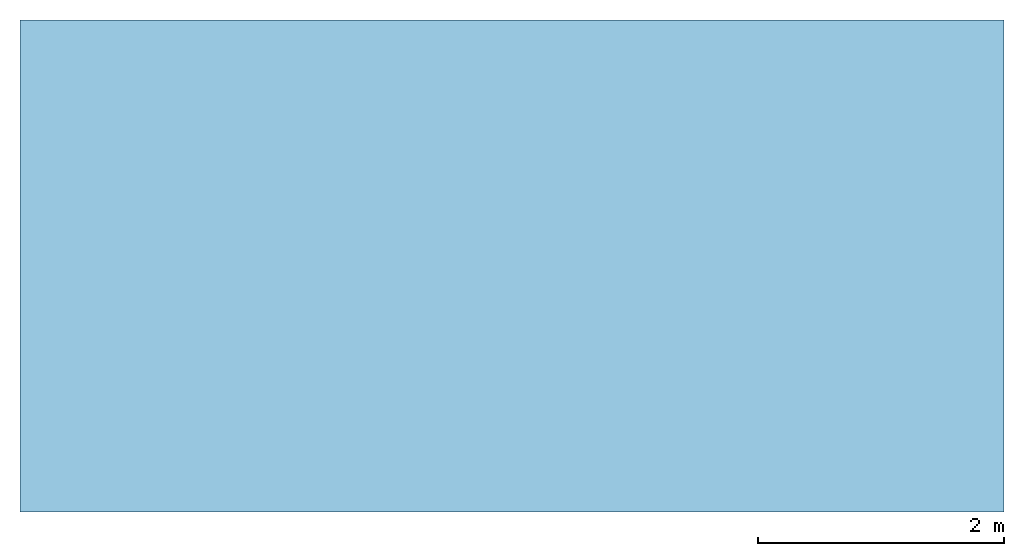
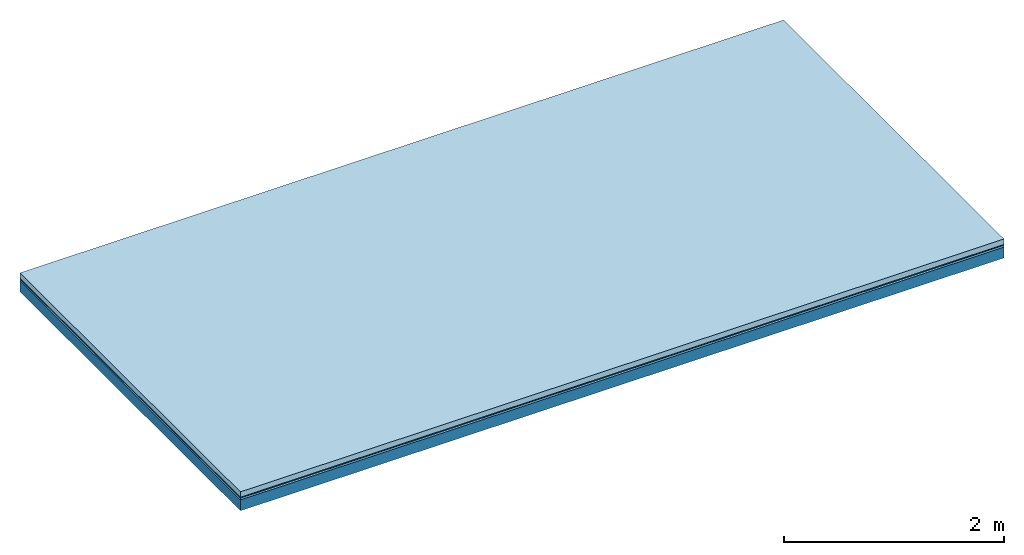
# One storey: 3 plates, 1 member, 1 element without a shape of its own.
"""IFC4 building model written with IfcOpenShell, lengths in metres."""

from ifc_helpers import new_model, si_unit, derived_unit, direction, frame, frame_2d, origin, origin_with_axes, place, context, project, spatial, rectangle, extrude, material, layer, layer_set, type_object, element, aggregate, save


model = new_model("IFC4")

# Units and contexts
plan_context = context("Plan", 3, precision=1e-05, world=origin(), true_north=direction((0.0, 1.0)))
model_context = context("Model", 3, precision=1e-05, world=origin(), true_north=direction((0.0, 1.0)))
ifc_project = project(units=[si_unit("LENGTHUNIT", "METRE"), derived_unit("SOUNDPRESSUREUNIT", [(si_unit("PRESSUREUNIT", "PASCAL", prefix="MICRO"), 0)]), si_unit("ENERGYUNIT", "JOULE", prefix="MEGA"), si_unit("MASSUNIT", "GRAM", prefix="KILO"), derived_unit("THERMALTRANSMITTANCEUNIT", [(si_unit("POWERUNIT", "WATT"), 1), (si_unit("AREAUNIT", "SQUARE_METRE"), -1), (si_unit("THERMODYNAMICTEMPERATUREUNIT", "KELVIN"), -1)]), derived_unit("AREADENSITYUNIT", [(si_unit("MASSUNIT", "GRAM", prefix="KILO"), 1), (si_unit("AREAUNIT", "SQUARE_METRE"), -1)]), derived_unit("USERDEFINED", [(si_unit("ENERGYUNIT", "JOULE", prefix="MEGA"), 1), (si_unit("AREAUNIT", "SQUARE_METRE"), -1)])], contexts=[plan_context, model_context])

# Site, building, storey
site = spatial("IfcSite", under=ifc_project)
building_placement = place(None, origin())
building = spatial("IfcBuilding", under=site, at=building_placement)
storey_placement = place(building_placement, origin())
storey = spatial("IfcBuildingStorey", under=building, at=storey_placement)

# Slab, member, plates
ifc_material_1 = material(Name="clay", Category="02.004")
ifc_layer_1 = layer(ifc_material_1, 0.06, Name="Use and protection layer 2")
ifc_material_2 = material(Name="Protective layer", Category="09.007")
ifc_layer_2 = layer(ifc_material_2, 0.01, Name="Use and protection layer 1")
ifc_material_3 = material(Name="Bituminous", Category="09.003")
ifc_layer_3 = layer(ifc_material_3, 0.02, Name="Seal")
ifc_material_4 = material(Name="no composite action")
ifc_layer_4 = layer(ifc_material_4, 0.0, Name="Bond")
ifc_layer_5 = layer(None, 0.12, Name="Support")
ifc_layer_set = layer_set([ifc_layer_1, ifc_layer_2, ifc_layer_3, ifc_layer_4, ifc_layer_5])
slab_type = type_object("IfcSlabType", Name="F0031", PredefinedType="NOTDEFINED", material=ifc_layer_set)
slab_placement = place(None, frame((0.0, 0.0, 0.0), z_axis=(0.0, 0.0, -1.0), x_axis=(1.0, 0.0, 0.0)))
slab = element("IfcSlab", 1, at=slab_placement, inside=storey, type_object=slab_type, material=ifc_layer_set, Name="Slab #1")
ifc_material_5 = material(Name="Solid timber panel")
member_placement = place(slab_placement, origin())
member = element("IfcMember", 2, at=member_placement, material=ifc_material_5, Name="Support", context=plan_context, shape_type="SweptSolid", body=[
    extrude(rectangle(XDim=1.0, YDim=0.12, at=frame_2d((0.5, 0.06), x_axis=(1.0, 0.0))), frame((0.0, 4.0, 0.09), z_axis=(0.0, -1.0, 0.0), x_axis=(1.0, 0.0, 0.0)), (0.0, 0.0, 1.0), 4.0),
    extrude(rectangle(XDim=1.0, YDim=0.12, at=frame_2d((0.5, 0.06), x_axis=(1.0, 0.0))), frame((1.0, 4.0, 0.09), z_axis=(0.0, -1.0, 0.0), x_axis=(1.0, 0.0, 0.0)), (0.0, 0.0, 1.0), 4.0),
    extrude(rectangle(XDim=1.0, YDim=0.12, at=frame_2d((0.5, 0.06), x_axis=(1.0, 0.0))), frame((2.0, 4.0, 0.09), z_axis=(0.0, -1.0, 0.0), x_axis=(1.0, 0.0, 0.0)), (0.0, 0.0, 1.0), 4.0),
    extrude(rectangle(XDim=1.0, YDim=0.12, at=frame_2d((0.5, 0.06), x_axis=(1.0, 0.0))), frame((3.0, 4.0, 0.09), z_axis=(0.0, -1.0, 0.0), x_axis=(1.0, 0.0, 0.0)), (0.0, 0.0, 1.0), 4.0),
    extrude(rectangle(XDim=1.0, YDim=0.12, at=frame_2d((0.5, 0.06), x_axis=(1.0, 0.0))), frame((4.0, 4.0, 0.09), z_axis=(0.0, -1.0, 0.0), x_axis=(1.0, 0.0, 0.0)), (0.0, 0.0, 1.0), 4.0),
    extrude(rectangle(XDim=1.0, YDim=0.12, at=frame_2d((0.5, 0.06), x_axis=(1.0, 0.0))), frame((5.0, 4.0, 0.09), z_axis=(0.0, -1.0, 0.0), x_axis=(1.0, 0.0, 0.0)), (0.0, 0.0, 1.0), 4.0),
    extrude(rectangle(XDim=1.0, YDim=0.12, at=frame_2d((0.5, 0.06), x_axis=(1.0, 0.0))), frame((6.0, 4.0, 0.09), z_axis=(0.0, -1.0, 0.0), x_axis=(1.0, 0.0, 0.0)), (0.0, 0.0, 1.0), 4.0),
    extrude(rectangle(XDim=1.0, YDim=0.12, at=frame_2d((0.5, 0.06), x_axis=(1.0, 0.0))), frame((7.0, 4.0, 0.09), z_axis=(0.0, -1.0, 0.0), x_axis=(1.0, 0.0, 0.0)), (0.0, 0.0, 1.0), 4.0),
])
plate_1_placement = place(slab_placement, origin())
plate_1 = element("IfcPlate", 3, at=plate_1_placement, material=ifc_material_1, Name="Use and protection layer 2", context=plan_context, shape_type="SweptSolid", body=[
    extrude(rectangle(XDim=8.0, YDim=4.0, at=frame_2d((4.0, 2.0), x_axis=(1.0, 0.0))), origin_with_axes(), (0.0, 0.0, 1.0), 0.06),
])
plate_2_placement = place(slab_placement, origin())
plate_2 = element("IfcPlate", 4, at=plate_2_placement, material=ifc_material_2, Name="Use and protection layer 1", context=plan_context, shape_type="SweptSolid", body=[
    extrude(rectangle(XDim=8.0, YDim=4.0, at=frame_2d((4.0, 2.0), x_axis=(1.0, 0.0))), frame((0.0, 0.0, 0.06), z_axis=(0.0, 0.0, 1.0), x_axis=(1.0, 0.0, 0.0)), (0.0, 0.0, 1.0), 0.01),
])
plate_3_placement = place(slab_placement, origin())
plate_3 = element("IfcPlate", 5, at=plate_3_placement, material=ifc_material_3, Name="Seal", context=plan_context, shape_type="SweptSolid", body=[
    extrude(rectangle(XDim=8.0, YDim=4.0, at=frame_2d((4.0, 2.0), x_axis=(1.0, 0.0))), frame((0.0, 0.0, 0.07), z_axis=(0.0, 0.0, 1.0), x_axis=(1.0, 0.0, 0.0)), (0.0, 0.0, 1.0), 0.02),
])
aggregate(slab, [plate_1, plate_2, plate_3, member])

save(model, "model.ifc")
